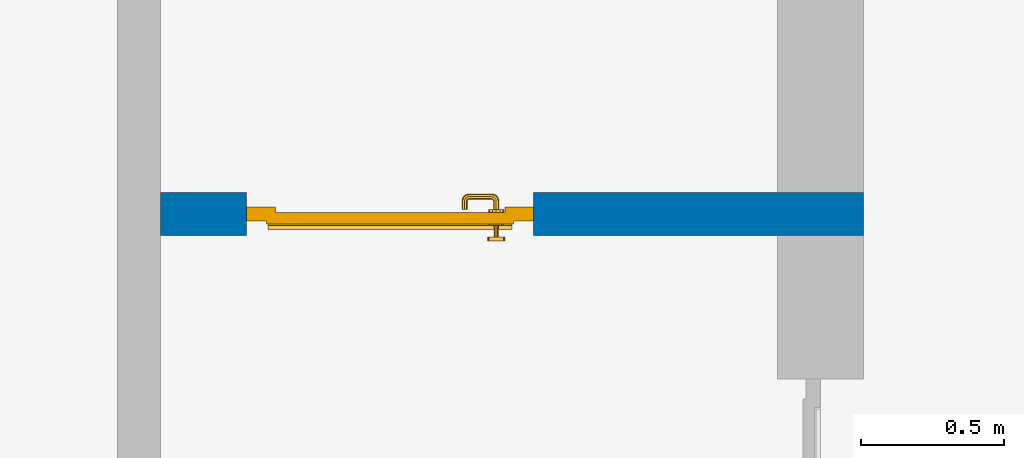
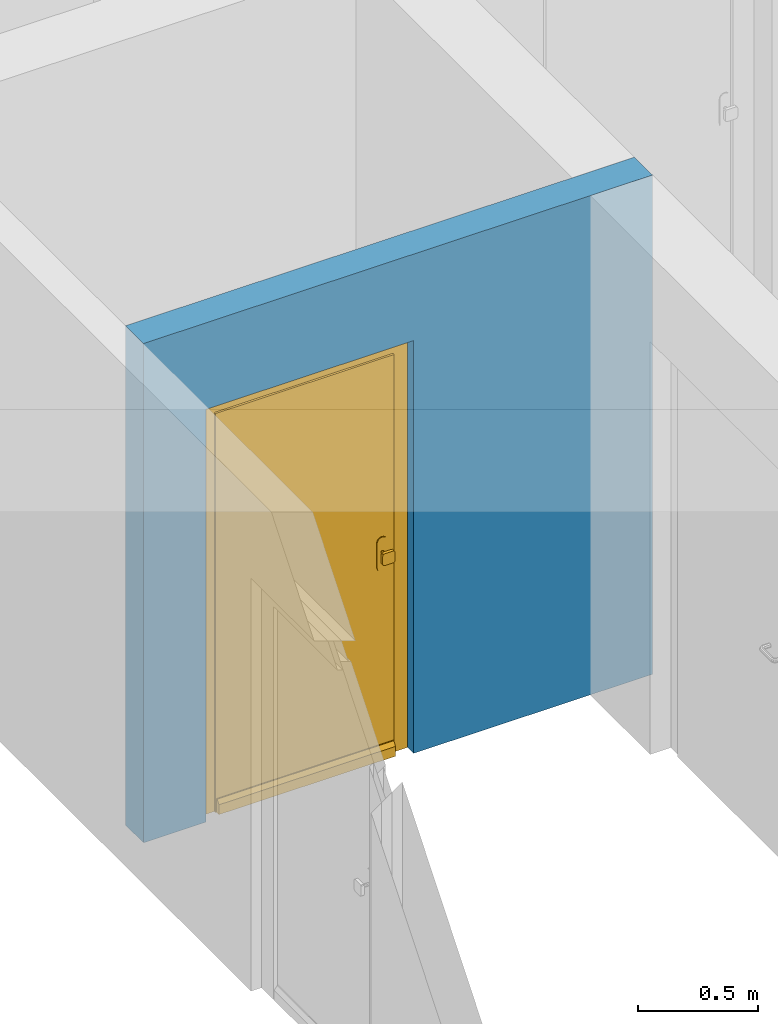
# One storey, part 5 of 54: 1 door, 1 wall, 1 opening.
"""IFC4 building model written with IfcOpenShell, lengths in metres."""

from ifc_helpers import new_model, entity, si_unit, converted_unit, derived_unit, direction, frame, origin_with_axes, place, context, subcontext, project, spatial, polygons, source, transform, mapped, material, type_object, element, fill, save


model = new_model("IFC4")

# Units and contexts
model_context = context("Model", 3, precision=1e-05, world=origin_with_axes(), true_north=direction((0.0, 1.0)))
body_context = subcontext(model_context, "Body", "Model", "MODEL_VIEW")
ifc_project = project(units=[si_unit("LENGTHUNIT", "METRE"), si_unit("AREAUNIT", "SQUARE_METRE"), si_unit("VOLUMEUNIT", "CUBIC_METRE"), converted_unit("PLANEANGLEUNIT", "DEGREE", entity("IfcPlaneAngleMeasure", 0.0174532925199), si_unit("PLANEANGLEUNIT", "RADIAN"), dimensions=[0, 0, 0, 0, 0, 0, 0]), converted_unit("TIMEUNIT", "Year", entity("IfcTimeMeasure", 31556926.0), si_unit("TIMEUNIT", "SECOND"), dimensions=[0, 0, 1, 0, 0, 0, 0]), si_unit("MASSUNIT", "GRAM", prefix="KILO"), si_unit("THERMODYNAMICTEMPERATUREUNIT", "DEGREE_CELSIUS"), si_unit("LUMINOUSINTENSITYUNIT", "LUMEN"), si_unit("ENERGYUNIT", "JOULE", prefix="MEGA"), derived_unit("THERMALCONDUCTANCEUNIT", [(si_unit("POWERUNIT", "WATT"), 1), (si_unit("LENGTHUNIT", "METRE"), -1), (si_unit("THERMODYNAMICTEMPERATUREUNIT", "KELVIN"), -1)]), derived_unit("SPECIFICHEATCAPACITYUNIT", [(si_unit("ENERGYUNIT", "JOULE"), 1), (si_unit("MASSUNIT", "GRAM", prefix="KILO"), -1), (si_unit("THERMODYNAMICTEMPERATUREUNIT", "KELVIN"), -1)]), derived_unit("MASSDENSITYUNIT", [(si_unit("MASSUNIT", "GRAM", prefix="KILO"), 1), (si_unit("VOLUMEUNIT", "CUBIC_METRE"), -1)])], contexts=[model_context])

# Site, building, storey
site_placement = place(None, origin_with_axes())
site = spatial("IfcSite", under=ifc_project, at=site_placement, CompositionType="ELEMENT")
building_placement = place(site_placement, origin_with_axes())
building = spatial("IfcBuilding", under=site, at=building_placement, CompositionType="ELEMENT")
storey_placement = place(building_placement, frame((0.0, 0.0, 6.29), z_axis=(0.0, 0.0, 1.0), x_axis=(1.0, 0.0, 0.0)))
storey = spatial("IfcBuildingStorey", under=building, at=storey_placement, Name="2. Geschoss", CompositionType="ELEMENT", Elevation=6.29)

# Wall, opening, door
ifc_material = material()
wall_type = type_object("IfcWallType", Name="150", PredefinedType="NOTDEFINED")
wall_placement = place(storey_placement, frame((-4.9421993804, -0.428812231043, 0.0), z_axis=(0.0, 0.0, 1.0), x_axis=(-1.0, 0.0, 0.0)))
wall = element("IfcWall", 1, at=wall_placement, inside=storey, type_object=wall_type, material=ifc_material, Name="Wand-002", PredefinedType="NOTDEFINED", context=body_context, shape_type="Tessellation", body=[
    polygons([(2.15, 0.0, 2.1), (2.15, 0.0, 0.0), (2.45, 0.0, 0.0), (2.45, 0.0, 2.54), (0.0, 0.0, 2.54), (0.0, 0.0, 0.0), (1.15, 0.0, 0.0), (1.15, 0.0, 2.1), (2.15, 0.1, 0.0), (2.15, 0.15, 2.1), (2.15, 0.15, 0.0), (2.45, 0.15, 0.0), (2.45, 0.15, 2.54), (0.0, 0.15, 2.54), (0.0, 0.15, 0.0), (1.15, 0.1, 0.0), (1.15, 0.15, 0.0), (1.15, 0.15, 2.1)], [[[1, 2, 3, 4, 5, 6, 7, 8]], [[9, 2, 1, 10, 11]], [[2, 9, 11, 12, 3]], [[4, 3, 12, 13]], [[5, 4, 13, 14]], [[14, 15, 6, 5]], [[16, 7, 6, 15, 17]], [[8, 7, 16, 17, 18]], [[1, 8, 18, 10]], [[12, 11, 10, 18, 17, 15, 14, 13]]], closed=True),
])
opening_placement = place(wall_placement, frame((1.65, 0.0, 0.0), z_axis=(0.0, 0.0, 1.0), x_axis=(1.0, 0.0, 0.0)))
opening = element("IfcOpeningElement", 2, at=opening_placement, cuts=wall, context=body_context, identifier="Reference", shape_type="Tessellation", body=[
    polygons([(-0.5, 0.1, 0.0), (-0.5, 0.1, 2.1), (-0.5, 0.151, 2.1), (-0.5, 0.151, 0.0), (-0.5, -0.001, 0.0), (-0.5, -0.001, 2.1), (0.5, 0.1, 2.1), (0.5, 0.151, 2.1), (0.5, -0.001, 2.1), (0.5, 0.151, 0.0), (0.5, 0.1, 0.0), (0.5, -0.001, 0.0)], [[[1, 2, 3, 4]], [[2, 1, 5, 6]], [[7, 8, 3, 2, 6, 9]], [[8, 10, 4, 3]], [[1, 4, 10, 11, 12, 5]], [[6, 5, 12, 9]], [[7, 11, 10, 8]], [[11, 7, 9, 12]]], closed=True),
])
door_type = type_object("IfcDoorType", Name="Eingang 01 1-Fl 26", OperationType="SINGLE_SWING_RIGHT", PredefinedType="DOOR")
shared_shape = source(origin_with_axes(), body_context, "Body", "Tessellation", [
    polygons([(0.5, -0.05, 0.0), (0.5, -0.03, 0.0), (0.5, -0.03, 2.1), (0.5, -0.05, 2.1), (0.4, -0.05, 0.0), (0.4, -0.03, 0.0), (0.4, -0.03, 2.0), (0.1301, -0.03, 2.0), (0.0001, -0.03, 2.0), (-0.4, -0.03, 2.0), (-0.4, -0.03, 0.0), (-0.5, -0.03, 0.0), (-0.5, -0.03, 2.1), (-0.5, -0.05, 2.1), (-0.5, -0.05, 0.0), (-0.4, -0.05, 0.0), (-0.4, -0.05, 2.0), (0.0001, -0.05, 2.0), (0.1301, -0.05, 2.0), (0.4, -0.05, 2.0)], [[[1, 2, 3, 4]], [[5, 6, 2, 1]], [[2, 6, 7, 8, 9, 10, 11, 12, 13, 3]], [[4, 3, 13, 14]], [[1, 4, 14, 15, 16, 17, 18, 19, 20, 5]], [[20, 7, 6, 5]], [[19, 8, 7, 20]], [[18, 9, 8, 19]], [[17, 10, 9, 18]], [[16, 11, 10, 17]], [[15, 12, 11, 16]], [[14, 13, 12, 15]]], closed=True),
    polygons([(0.5, -0.03, 0.0), (0.5, 0.0, 0.0), (0.5, 0.0, 2.1), (0.5, -0.03, 2.1), (0.43, -0.03, 0.0), (0.43, 0.0, 0.0), (0.43, 0.0, 2.03), (0.1001, 0.0, 2.03), (0.0301, 0.0, 2.03), (-0.43, 0.0, 2.03), (-0.43, 0.0, 0.0), (-0.5, 0.0, 0.0), (-0.5, 0.0, 2.1), (-0.5, -0.03, 2.1), (-0.5, -0.03, 0.0), (-0.43, -0.03, 0.0), (-0.43, -0.03, 2.03), (0.0301, -0.03, 2.03), (0.1001, -0.03, 2.03), (0.43, -0.03, 2.03)], [[[1, 2, 3, 4]], [[5, 6, 2, 1]], [[2, 6, 7, 8, 9, 10, 11, 12, 13, 3]], [[4, 3, 13, 14]], [[1, 4, 14, 15, 16, 17, 18, 19, 20, 5]], [[20, 7, 6, 5]], [[19, 8, 7, 20]], [[18, 9, 8, 19]], [[17, 10, 9, 18]], [[16, 11, 10, 17]], [[15, 12, 11, 16]], [[14, 13, 12, 15]]], closed=True),
    polygons([(0.43, 0.01, 0.0), (-0.43, 0.01, 0.0), (-0.43, 0.01, 2.03), (0.43, 0.01, 2.03), (0.43, -0.03, 0.0), (-0.43, -0.03, 0.0), (-0.43, -0.03, 2.03), (0.43, -0.03, 2.03)], [[[1, 2, 3, 4]], [[2, 1, 5, 6]], [[3, 2, 6, 7]], [[4, 3, 7, 8]], [[1, 4, 8, 5]], [[6, 5, 8, 7]]], closed=True),
    polygons([(0.425, 0.03, 0.0), (-0.425, 0.03, 0.0), (-0.425, 0.03, 0.05), (0.425, 0.03, 0.05), (0.425, 0.01, 0.0), (-0.425, 0.01, 0.0), (-0.425, 0.01, 0.07), (-0.425, 0.015, 0.07), (0.425, 0.015, 0.07), (0.425, 0.01, 0.07)], [[[1, 2, 3, 4]], [[5, 6, 2, 1]], [[2, 6, 7, 8, 3]], [[4, 3, 8, 9]], [[1, 4, 9, 10, 5]], [[10, 7, 6, 5]], [[9, 8, 7, 10]]], closed=True),
    polygons([(-0.3835, -0.04, 1.0733826859), (-0.37, -0.04, 1.077), (-0.37, -0.0399, 1.077), (-0.3835, -0.0399, 1.0733826859), (-0.393382685902, -0.04, 1.0635), (-0.397, -0.04, 1.05), (-0.393382685902, -0.04, 1.0365), (-0.3835, -0.04, 1.0266173141), (-0.37, -0.04, 1.023), (-0.3565, -0.04, 1.0266173141), (-0.346617314098, -0.04, 1.0365), (-0.343, -0.04, 1.05), (-0.346617314098, -0.04, 1.0635), (-0.3565, -0.04, 1.0733826859), (-0.3565, -0.0399, 1.0733826859), (-0.37, -0.0301, 1.077), (-0.3835, -0.0301, 1.0733826859), (-0.393382685902, -0.0399, 1.0635), (-0.397, -0.0399, 1.05), (-0.393382685902, -0.0399, 1.0365), (-0.3835, -0.0399, 1.0266173141), (-0.37, -0.0399, 1.023), (-0.3565, -0.0399, 1.0266173141), (-0.346617314098, -0.0399, 1.0365), (-0.343, -0.0399, 1.05), (-0.346617314098, -0.0399, 1.0635), (-0.3565, -0.0301, 1.0733826859), (-0.37, -0.03, 1.077), (-0.3835, -0.03, 1.0733826859), (-0.393382685902, -0.0301, 1.0635), (-0.397, -0.0301, 1.05), (-0.393382685902, -0.0301, 1.0365), (-0.3835, -0.0301, 1.0266173141), (-0.37, -0.0301, 1.023), (-0.3565, -0.0301, 1.0266173141), (-0.346617314098, -0.0301, 1.0365), (-0.343, -0.0301, 1.05), (-0.346617314098, -0.0301, 1.0635), (-0.3565, -0.03, 1.0733826859), (-0.346617314098, -0.03, 1.0635), (-0.343, -0.03, 1.05), (-0.346617314098, -0.03, 1.0365), (-0.3565, -0.03, 1.0266173141), (-0.37, -0.03, 1.023), (-0.3835, -0.03, 1.0266173141), (-0.393382685902, -0.03, 1.0365), (-0.397, -0.03, 1.05), (-0.393382685902, -0.03, 1.0635)], [[[1, 2, 3, 4]], [[2, 1, 5, 6, 7, 8, 9, 10, 11, 12, 13, 14]], [[2, 14, 15, 3]], [[4, 3, 16, 17]], [[5, 1, 4, 18]], [[6, 5, 18, 19]], [[7, 6, 19, 20]], [[8, 7, 20, 21]], [[9, 8, 21, 22]], [[10, 9, 22, 23]], [[11, 10, 23, 24]], [[12, 11, 24, 25]], [[13, 12, 25, 26]], [[14, 13, 26, 15]], [[3, 15, 27, 16]], [[17, 16, 28, 29]], [[18, 4, 17, 30]], [[19, 18, 30, 31]], [[20, 19, 31, 32]], [[21, 20, 32, 33]], [[22, 21, 33, 34]], [[23, 22, 34, 35]], [[24, 23, 35, 36]], [[25, 24, 36, 37]], [[26, 25, 37, 38]], [[15, 26, 38, 27]], [[16, 27, 39, 28]], [[28, 39, 40, 41, 42, 43, 44, 45, 46, 47, 48, 29]], [[30, 17, 29, 48]], [[31, 30, 48, 47]], [[32, 31, 47, 46]], [[33, 32, 46, 45]], [[34, 33, 45, 44]], [[35, 34, 44, 43]], [[36, 35, 43, 42]], [[37, 36, 42, 41]], [[38, 37, 41, 40]], [[27, 38, 40, 39]]], closed=True),
    polygons([(-0.362532169224, -0.04, 0.959692280177), (-0.365, -0.04, 0.9544), (-0.365, -0.04, 0.952886751346), (-0.346703916638, -0.04, 0.96345), (-0.35655, -0.04, 0.973296083362), (-0.363279754556, -0.04, 0.961639806549), (-0.362532169224, -0.039, 0.959692280177), (-0.365, -0.039, 0.9544), (-0.365, -0.039, 0.952886751346), (-0.365, -0.039, 0.95), (-0.365, -0.039, 0.947113248654), (-0.365, -0.039, 0.941339745962), (-0.365, -0.039, 0.9375), (-0.365, -0.04, 0.9375), (-0.365, -0.04, 0.941339745962), (-0.365, -0.04, 0.947113248654), (-0.365, -0.04, 0.95), (-0.3431, -0.04, 0.95), (-0.346617314098, -0.04, 0.9635), (-0.3565, -0.04, 0.973382685902), (-0.364624817685, -0.04, 0.965143815798), (-0.37, -0.04, 0.9769), (-0.37, -0.04, 0.967425445323), (-0.364624817685, -0.039, 0.965143815798), (-0.363279754556, -0.039, 0.961639806549), (-0.35705, -0.039, 0.972430057958), (-0.347569942042, -0.039, 0.96295), (-0.3441, -0.039, 0.95), (-0.347569942042, -0.039, 0.93705), (-0.35705, -0.039, 0.927569942042), (-0.37, -0.039, 0.9241), (-0.37, -0.039, 0.9325), (-0.366464466094, -0.039, 0.933964466094), (-0.366464466094, -0.04, 0.933964466094), (-0.35655, -0.04, 0.926703916638), (-0.37, -0.04, 0.9325), (-0.37, -0.04, 0.9231), (-0.346703916638, -0.04, 0.93655), (-0.343, -0.04, 0.95), (-0.346617314098, -0.0399, 0.9635), (-0.3565, -0.0399, 0.973382685902), (-0.37, -0.04, 0.977), (-0.375375182315, -0.04, 0.965143815798), (-0.38345, -0.04, 0.973296083362), (-0.376720245444, -0.04, 0.961639806549), (-0.37, -0.039, 0.967425445323), (-0.37, -0.039, 0.9759), (-0.357, -0.039, 0.972516660498), (-0.347483339502, -0.039, 0.963), (-0.344, -0.039, 0.95), (-0.347483339502, -0.039, 0.937), (-0.357, -0.039, 0.927483339502), (-0.38295, -0.039, 0.927569942042), (-0.375, -0.039, 0.941339745962), (-0.375, -0.039, 0.9375), (-0.373535533906, -0.039, 0.933964466094), (-0.37, -0.039, 0.924), (-0.373535533906, -0.04, 0.933964466094), (-0.375, -0.04, 0.9375), (-0.375, -0.04, 0.941339745962), (-0.38345, -0.04, 0.926703916638), (-0.37, -0.04, 0.923), (-0.3565, -0.04, 0.926617314098), (-0.346617314098, -0.04, 0.9365), (-0.343, -0.0399, 0.95), (-0.346617314098, -0.0301, 0.9635), (-0.3565, -0.0301, 0.973382685902), (-0.37, -0.0399, 0.977), (-0.3835, -0.04, 0.973382685902), (-0.375375182315, -0.039, 0.965143815798), (-0.377467830776, -0.04, 0.959692280177), (-0.393296083362, -0.04, 0.96345), (-0.375, -0.04, 0.952886751346), (-0.375, -0.04, 0.9544), (-0.377467830776, -0.039, 0.959692280177), (-0.376720245444, -0.039, 0.961639806549), (-0.38295, -0.039, 0.972430057958), (-0.37, -0.039, 0.976), (-0.357, -0.0389, 0.972516660498), (-0.347483339502, -0.0389, 0.963), (-0.344, -0.0389, 0.95), (-0.347483339502, -0.0389, 0.937), (-0.357, -0.0389, 0.927483339502), (-0.392430057958, -0.039, 0.93705), (-0.375, -0.039, 0.947113248654), (-0.375, -0.039, 0.9544), (-0.375, -0.04, 0.95), (-0.375, -0.04, 0.947113248654), (-0.375, -0.039, 0.95), (-0.375, -0.039, 0.952886751346), (-0.383, -0.039, 0.927483339502), (-0.37, -0.0389, 0.924), (-0.393296083362, -0.04, 0.93655), (-0.3835, -0.04, 0.926617314098), (-0.37, -0.0399, 0.923), (-0.3565, -0.0399, 0.926617314098), (-0.346617314098, -0.0399, 0.9365), (-0.343, -0.0301, 0.95), (-0.346617314098, -0.03, 0.9635), (-0.3565, -0.03, 0.973382685902), (-0.37, -0.0301, 0.977), (-0.3835, -0.0399, 0.973382685902), (-0.393382685902, -0.04, 0.9635), (-0.3969, -0.04, 0.95), (-0.392430057958, -0.039, 0.96295), (-0.383, -0.039, 0.972516660498), (-0.37, -0.0389, 0.976), (-0.357, -0.0301, 0.972516660498), (-0.347483339502, -0.0301, 0.963), (-0.344, -0.0301, 0.95), (-0.347483339502, -0.0301, 0.937), (-0.357, -0.0301, 0.927483339502), (-0.392516660498, -0.039, 0.937), (-0.3959, -0.039, 0.95), (-0.383, -0.0389, 0.927483339502), (-0.37, -0.0301, 0.924), (-0.393382685902, -0.04, 0.9365), (-0.3835, -0.0399, 0.926617314098), (-0.37, -0.0301, 0.923), (-0.3565, -0.0301, 0.926617314098), (-0.346617314098, -0.0301, 0.9365), (-0.343, -0.03, 0.95), (-0.346703916638, -0.03, 0.96345), (-0.35655, -0.03, 0.973296083362), (-0.37, -0.03, 0.977), (-0.3835, -0.0301, 0.973382685902), (-0.393382685902, -0.0399, 0.9635), (-0.397, -0.04, 0.95), (-0.392516660498, -0.039, 0.963), (-0.383, -0.0389, 0.972516660498), (-0.37, -0.0301, 0.976), (-0.357, -0.03, 0.972516660498), (-0.347483339502, -0.03, 0.963), (-0.344, -0.03, 0.95), (-0.347483339502, -0.03, 0.937), (-0.357, -0.03, 0.927483339502), (-0.392516660498, -0.0389, 0.937), (-0.396, -0.039, 0.95), (-0.383, -0.0301, 0.927483339502), (-0.37, -0.03, 0.924), (-0.393382685902, -0.0399, 0.9365), (-0.3835, -0.0301, 0.926617314098), (-0.37, -0.03, 0.923), (-0.3565, -0.03, 0.926617314098), (-0.346617314098, -0.03, 0.9365), (-0.3431, -0.03, 0.95), (-0.347396736961, -0.03, 0.96305), (-0.35695, -0.03, 0.972603263039), (-0.37, -0.03, 0.9769), (-0.3835, -0.03, 0.973382685902), (-0.393382685902, -0.0301, 0.9635), (-0.397, -0.0399, 0.95), (-0.392516660498, -0.0389, 0.963), (-0.383, -0.0301, 0.972516660498), (-0.37, -0.03, 0.976), (-0.3439, -0.03, 0.95), (-0.347396736961, -0.03, 0.93695), (-0.35695, -0.03, 0.927396736961), (-0.392516660498, -0.0301, 0.937), (-0.396, -0.0389, 0.95), (-0.383, -0.03, 0.927483339502), (-0.37, -0.03, 0.9239), (-0.393382685902, -0.0301, 0.9365), (-0.3835, -0.03, 0.926617314098), (-0.37, -0.03, 0.9231), (-0.35655, -0.03, 0.926703916638), (-0.346703916638, -0.03, 0.93655), (-0.37, -0.03, 0.9761), (-0.38345, -0.03, 0.973296083362), (-0.393382685902, -0.03, 0.9635), (-0.397, -0.0301, 0.95), (-0.392516660498, -0.0301, 0.963), (-0.383, -0.03, 0.972516660498), (-0.392516660498, -0.03, 0.937), (-0.396, -0.0301, 0.95), (-0.38305, -0.03, 0.927396736961), (-0.393382685902, -0.03, 0.9365), (-0.38345, -0.03, 0.926703916638), (-0.38305, -0.03, 0.972603263039), (-0.393296083362, -0.03, 0.96345), (-0.397, -0.03, 0.95), (-0.392516660498, -0.03, 0.963), (-0.392603263039, -0.03, 0.93695), (-0.396, -0.03, 0.95), (-0.393296083362, -0.03, 0.93655), (-0.392603263039, -0.03, 0.96305), (-0.3969, -0.03, 0.95), (-0.3961, -0.03, 0.95)], [[[1, 2, 3, 4, 5, 6]], [[2, 1, 7, 8]], [[2, 8, 9, 10, 11, 12, 13, 14, 15, 16, 17, 3]], [[17, 18, 4, 3]], [[19, 20, 5, 4]], [[21, 6, 5, 22, 23]], [[1, 6, 21, 24, 25, 7]], [[7, 25, 26, 27, 9, 8]], [[9, 27, 28, 10]], [[10, 28, 29, 11]], [[11, 29, 30, 12]], [[31, 32, 33, 13, 12, 30]], [[14, 13, 33, 34]], [[35, 15, 14, 34, 36, 37]], [[15, 35, 38, 16]], [[16, 38, 18, 17]], [[39, 19, 4, 18]], [[40, 41, 20, 19]], [[20, 42, 22, 5]], [[43, 23, 22, 44, 45]], [[21, 23, 46, 24]], [[24, 46, 47, 26, 25]], [[27, 26, 48, 49]], [[28, 27, 49, 50]], [[29, 28, 50, 51]], [[30, 29, 51, 52]], [[53, 54, 55, 56, 32, 31]], [[34, 33, 32, 36]], [[31, 30, 52, 57]], [[37, 36, 58, 59, 60, 61]], [[62, 63, 35, 37]], [[63, 64, 38, 35]], [[64, 39, 18, 38]], [[65, 40, 19, 39]], [[66, 67, 41, 40]], [[41, 68, 42, 20]], [[42, 69, 44, 22]], [[23, 43, 70, 46]], [[71, 45, 44, 72, 73, 74]], [[43, 45, 71, 75, 76, 70]], [[70, 76, 77, 47, 46]], [[26, 47, 78, 48]], [[49, 48, 79, 80]], [[50, 49, 80, 81]], [[51, 50, 81, 82]], [[52, 51, 82, 83]], [[54, 53, 84, 85]], [[86, 74, 73, 87, 88, 60, 59, 55, 54, 85, 89, 90]], [[58, 56, 55, 59]], [[36, 32, 56, 58]], [[53, 31, 57, 91]], [[57, 52, 83, 92]], [[88, 93, 61, 60]], [[94, 62, 37, 61]], [[95, 96, 63, 62]], [[96, 97, 64, 63]], [[97, 65, 39, 64]], [[98, 66, 40, 65]], [[99, 100, 67, 66]], [[67, 101, 68, 41]], [[68, 102, 69, 42]], [[69, 103, 72, 44]], [[73, 72, 104, 87]], [[71, 74, 86, 75]], [[75, 86, 90, 105, 77, 76]], [[47, 77, 106, 78]], [[48, 78, 107, 79]], [[80, 79, 108, 109]], [[81, 80, 109, 110]], [[82, 81, 110, 111]], [[83, 82, 111, 112]], [[84, 53, 91, 113]], [[85, 84, 114, 89]], [[87, 104, 93, 88]], [[89, 114, 105, 90]], [[91, 57, 92, 115]], [[92, 83, 112, 116]], [[117, 94, 61, 93]], [[118, 95, 62, 94]], [[119, 120, 96, 95]], [[120, 121, 97, 96]], [[121, 98, 65, 97]], [[122, 99, 66, 98]], [[123, 124, 100, 99]], [[100, 125, 101, 67]], [[101, 126, 102, 68]], [[102, 127, 103, 69]], [[103, 128, 104, 72]], [[77, 105, 129, 106]], [[78, 106, 130, 107]], [[79, 107, 131, 108]], [[109, 108, 132, 133]], [[110, 109, 133, 134]], [[111, 110, 134, 135]], [[112, 111, 135, 136]], [[113, 91, 115, 137]], [[114, 84, 113, 138]], [[128, 117, 93, 104]], [[105, 114, 138, 129]], [[115, 92, 116, 139]], [[116, 112, 136, 140]], [[141, 118, 94, 117]], [[142, 119, 95, 118]], [[143, 144, 120, 119]], [[144, 145, 121, 120]], [[145, 122, 98, 121]], [[146, 123, 99, 122]], [[147, 148, 124, 123]], [[124, 149, 125, 100]], [[125, 150, 126, 101]], [[126, 151, 127, 102]], [[127, 152, 128, 103]], [[106, 129, 153, 130]], [[107, 130, 154, 131]], [[108, 131, 155, 132]], [[133, 132, 148, 147]], [[134, 133, 147, 156]], [[135, 134, 156, 157]], [[136, 135, 157, 158]], [[137, 115, 139, 159]], [[138, 113, 137, 160]], [[152, 141, 117, 128]], [[129, 138, 160, 153]], [[139, 116, 140, 161]], [[140, 136, 158, 162]], [[163, 142, 118, 141]], [[164, 143, 119, 142]], [[165, 166, 144, 143]], [[166, 167, 145, 144]], [[167, 146, 122, 145]], [[156, 147, 123, 146]], [[148, 168, 149, 124]], [[149, 169, 150, 125]], [[150, 170, 151, 126]], [[151, 171, 152, 127]], [[130, 153, 172, 154]], [[131, 154, 173, 155]], [[132, 155, 168, 148]], [[157, 156, 146, 167]], [[158, 157, 167, 166]], [[159, 139, 161, 174]], [[160, 137, 159, 175]], [[171, 163, 141, 152]], [[153, 160, 175, 172]], [[161, 140, 162, 176]], [[162, 158, 166, 165]], [[177, 164, 142, 163]], [[178, 165, 143, 164]], [[168, 179, 169, 149]], [[169, 180, 170, 150]], [[170, 181, 171, 151]], [[154, 172, 182, 173]], [[155, 173, 179, 168]], [[174, 161, 176, 183]], [[175, 159, 174, 184]], [[181, 177, 163, 171]], [[172, 175, 184, 182]], [[176, 162, 165, 178]], [[185, 178, 164, 177]], [[179, 186, 180, 169]], [[180, 187, 181, 170]], [[173, 182, 186, 179]], [[183, 176, 178, 185]], [[184, 174, 183, 188]], [[187, 185, 177, 181]], [[182, 184, 188, 186]], [[186, 188, 187, 180]], [[188, 183, 185, 187]]], closed=True),
    polygons([(-0.38, -0.04, 1.05), (-0.377071067812, -0.04, 1.04292893219), (-0.377071067812, -0.070696439392, 1.04292893219), (-0.38, -0.0709849140336, 1.05), (-0.37, -0.04, 1.04), (-0.37, -0.07, 1.04), (-0.375518993221, -0.0784992452783, 1.04292893219), (-0.378277987014, -0.0796420579258, 1.05), (-0.377071067812, -0.04, 1.05707106781), (-0.377071067812, -0.070696439392, 1.05707106781), (-0.362928932188, -0.04, 1.04292893219), (-0.362928932188, -0.069303560608, 1.04292893219), (-0.368858192988, -0.0757402514855, 1.04), (-0.370704557509, -0.0857045575088, 1.04292893219), (-0.372816199938, -0.0878161999379, 1.05), (-0.375518993221, -0.0784992452783, 1.05707106781), (-0.37, -0.04, 1.06), (-0.37, -0.07, 1.06), (-0.36, -0.04, 1.05), (-0.36, -0.0690150859664, 1.05), (-0.362197392755, -0.0729812576926, 1.04292893219), (-0.365606601718, -0.0806066017178, 1.04), (-0.363499245278, -0.0905189932208, 1.04292893219), (-0.364642057926, -0.0932779870137, 1.05), (-0.370704557509, -0.0857045575088, 1.05707106781), (-0.368858192988, -0.0757402514855, 1.06), (-0.362928932188, -0.04, 1.05707106781), (-0.362928932188, -0.069303560608, 1.05707106781), (-0.359438398962, -0.0718384450452, 1.05), (-0.360508645927, -0.0755086459268, 1.04292893219), (-0.360740251485, -0.0838581929877, 1.04), (-0.355696439392, -0.0920710678119, 1.04292893219), (-0.355984914034, -0.095, 1.05), (-0.363499245278, -0.0905189932208, 1.05707106781), (-0.365606601718, -0.0806066017178, 1.06), (-0.362197392755, -0.0729812576926, 1.05707106781), (-0.358397003498, -0.0733970034977, 1.05), (-0.357981257693, -0.0771973927545, 1.04292893219), (-0.355, -0.085, 1.04), (-0.274303560608, -0.0920710678119, 1.04292893219), (-0.274015085966, -0.095, 1.05), (-0.355696439392, -0.0920710678119, 1.05707106781), (-0.360740251485, -0.0838581929877, 1.06), (-0.360508645927, -0.0755086459268, 1.05707106781), (-0.356838445045, -0.0744383989617, 1.05), (-0.354303560608, -0.0779289321881, 1.04292893219), (-0.275, -0.085, 1.04), (-0.266500754722, -0.0905189932208, 1.04292893219), (-0.265357942074, -0.0932779870137, 1.05), (-0.274303560608, -0.0920710678119, 1.05707106781), (-0.355, -0.085, 1.06), (-0.357981257693, -0.0771973927545, 1.05707106781), (-0.354015085966, -0.075, 1.05), (-0.275696439392, -0.0779289321881, 1.04292893219), (-0.269259748515, -0.0838581929877, 1.04), (-0.259295442491, -0.0857045575088, 1.04292893219), (-0.257183800062, -0.0878161999379, 1.05), (-0.266500754722, -0.0905189932208, 1.05707106781), (-0.275, -0.085, 1.06), (-0.354303560608, -0.0779289321881, 1.05707106781), (-0.275984914034, -0.075, 1.05), (-0.272018742307, -0.0771973927545, 1.04292893219), (-0.264393398282, -0.0806066017178, 1.04), (-0.254481006779, -0.0784992452783, 1.04292893219), (-0.251722012986, -0.0796420579258, 1.05), (-0.259295442491, -0.0857045575088, 1.05707106781), (-0.269259748515, -0.0838581929877, 1.06), (-0.275696439392, -0.0779289321881, 1.05707106781), (-0.273161554955, -0.0744383989617, 1.05), (-0.269491354073, -0.0755086459268, 1.04292893219), (-0.261141807012, -0.0757402514855, 1.04), (-0.252928932188, -0.070696439392, 1.04292893219), (-0.25, -0.0709849140336, 1.05), (-0.254481006779, -0.0784992452783, 1.05707106781), (-0.264393398282, -0.0806066017178, 1.06), (-0.272018742307, -0.0771973927545, 1.05707106781), (-0.271602996502, -0.0733970034977, 1.05), (-0.267802607245, -0.0729812576926, 1.04292893219), (-0.26, -0.07, 1.04), (-0.252928932188, -0.04, 1.04292893219), (-0.25, -0.04, 1.05), (-0.252928932188, -0.070696439392, 1.05707106781), (-0.261141807012, -0.0757402514855, 1.06), (-0.269491354073, -0.0755086459268, 1.05707106781), (-0.270561601038, -0.0718384450452, 1.05), (-0.267071067812, -0.069303560608, 1.04292893219), (-0.26, -0.04, 1.04), (-0.267071067812, -0.04, 1.04292893219), (-0.27, -0.04, 1.05), (-0.267071067812, -0.04, 1.05707106781), (-0.26, -0.04, 1.06), (-0.252928932188, -0.04, 1.05707106781), (-0.26, -0.07, 1.06), (-0.267802607245, -0.0729812576926, 1.05707106781), (-0.27, -0.0690150859664, 1.05), (-0.267071067812, -0.069303560608, 1.05707106781)], [[[1, 2, 3, 4]], [[2, 5, 6, 3]], [[4, 3, 7, 8]], [[9, 1, 4, 10]], [[5, 11, 12, 6]], [[3, 6, 13, 7]], [[8, 7, 14, 15]], [[10, 4, 8, 16]], [[17, 9, 10, 18]], [[11, 19, 20, 12]], [[6, 12, 21, 13]], [[7, 13, 22, 14]], [[15, 14, 23, 24]], [[16, 8, 15, 25]], [[18, 10, 16, 26]], [[27, 17, 18, 28]], [[19, 27, 28, 20]], [[12, 20, 29, 21]], [[13, 21, 30, 22]], [[14, 22, 31, 23]], [[24, 23, 32, 33]], [[25, 15, 24, 34]], [[26, 16, 25, 35]], [[28, 18, 26, 36]], [[20, 28, 36, 29]], [[21, 29, 37, 30]], [[22, 30, 38, 31]], [[23, 31, 39, 32]], [[33, 32, 40, 41]], [[34, 24, 33, 42]], [[35, 25, 34, 43]], [[36, 26, 35, 44]], [[29, 36, 44, 37]], [[30, 37, 45, 38]], [[31, 38, 46, 39]], [[32, 39, 47, 40]], [[41, 40, 48, 49]], [[42, 33, 41, 50]], [[43, 34, 42, 51]], [[44, 35, 43, 52]], [[37, 44, 52, 45]], [[38, 45, 53, 46]], [[39, 46, 54, 47]], [[40, 47, 55, 48]], [[49, 48, 56, 57]], [[50, 41, 49, 58]], [[51, 42, 50, 59]], [[52, 43, 51, 60]], [[45, 52, 60, 53]], [[46, 53, 61, 54]], [[47, 54, 62, 55]], [[48, 55, 63, 56]], [[57, 56, 64, 65]], [[58, 49, 57, 66]], [[59, 50, 58, 67]], [[60, 51, 59, 68]], [[53, 60, 68, 61]], [[54, 61, 69, 62]], [[55, 62, 70, 63]], [[56, 63, 71, 64]], [[65, 64, 72, 73]], [[66, 57, 65, 74]], [[67, 58, 66, 75]], [[68, 59, 67, 76]], [[61, 68, 76, 69]], [[62, 69, 77, 70]], [[63, 70, 78, 71]], [[64, 71, 79, 72]], [[73, 72, 80, 81]], [[74, 65, 73, 82]], [[75, 66, 74, 83]], [[76, 67, 75, 84]], [[69, 76, 84, 77]], [[70, 77, 85, 78]], [[71, 78, 86, 79]], [[72, 79, 87, 80]], [[81, 80, 87, 88, 89, 90, 91, 92]], [[82, 73, 81, 92]], [[83, 74, 82, 93]], [[84, 75, 83, 94]], [[77, 84, 94, 85]], [[78, 85, 95, 86]], [[79, 86, 88, 87]], [[86, 95, 89, 88]], [[95, 96, 90, 89]], [[96, 93, 91, 90]], [[93, 82, 92, 91]], [[94, 83, 93, 96]], [[85, 94, 96, 95]]], closed=False),
    polygons([(-0.364696699141, 0.015, 1.04469669914), (-0.3625, 0.015, 1.05), (-0.364696699141, 0.015, 1.05530330086), (-0.37, 0.015, 1.0575), (-0.375303300859, 0.015, 1.05530330086), (-0.3775, 0.015, 1.05), (-0.375303300859, 0.015, 1.04469669914), (-0.37, 0.015, 1.0425), (-0.364696699141, 0.055, 1.04469669914), (-0.3625, 0.055, 1.05), (-0.364696699141, 0.055, 1.05530330086), (-0.37, 0.055, 1.0575), (-0.375303300859, 0.055, 1.05530330086), (-0.3775, 0.055, 1.05), (-0.375303300859, 0.055, 1.04469669914), (-0.37, 0.055, 1.0425)], [[[1, 2, 3, 4, 5, 6, 7, 8]], [[1, 9, 10, 2]], [[2, 10, 11, 3]], [[3, 11, 12, 4]], [[4, 12, 13, 5]], [[5, 13, 14, 6]], [[6, 14, 15, 7]], [[7, 15, 16, 8]], [[8, 16, 9, 1]], [[9, 16, 15, 14, 13, 12, 11, 10]]], closed=True),
    polygons([(-0.395, 0.01, 0.975), (-0.395, 0.015, 0.975), (-0.393096988313, 0.015, 0.965432914191), (-0.393096988313, 0.01, 0.965432914191), (-0.395, 0.01, 1.1), (-0.395, 0.015, 1.1), (-0.393096988313, 0.015, 1.10956708581), (-0.38767766953, 0.015, 1.11767766953), (-0.379567085809, 0.015, 1.12309698831), (-0.37, 0.015, 1.125), (-0.360432914191, 0.015, 1.12309698831), (-0.35232233047, 0.015, 1.11767766953), (-0.346903011687, 0.015, 1.10956708581), (-0.345, 0.015, 1.1), (-0.345, 0.015, 0.975), (-0.346903011687, 0.015, 0.965432914191), (-0.35232233047, 0.015, 0.95732233047), (-0.360432914191, 0.015, 0.951903011687), (-0.37, 0.015, 0.95), (-0.379567085809, 0.015, 0.951903011687), (-0.38767766953, 0.015, 0.95732233047), (-0.38767766953, 0.01, 0.95732233047), (-0.379567085809, 0.01, 0.951903011687), (-0.37, 0.01, 0.95), (-0.360432914191, 0.01, 0.951903011687), (-0.35232233047, 0.01, 0.95732233047), (-0.346903011687, 0.01, 0.965432914191), (-0.345, 0.01, 0.975), (-0.345, 0.01, 1.1), (-0.346903011687, 0.01, 1.10956708581), (-0.35232233047, 0.01, 1.11767766953), (-0.360432914191, 0.01, 1.12309698831), (-0.37, 0.01, 1.125), (-0.379567085809, 0.01, 1.12309698831), (-0.38767766953, 0.01, 1.11767766953), (-0.393096988313, 0.01, 1.10956708581)], [[[1, 2, 3, 4]], [[5, 6, 2, 1]], [[2, 6, 7, 8, 9, 10, 11, 12, 13, 14, 15, 16, 17, 18, 19, 20, 21, 3]], [[4, 3, 21, 22]], [[1, 4, 22, 23, 24, 25, 26, 27, 28, 29, 30, 31, 32, 33, 34, 35, 36, 5]], [[36, 7, 6, 5]], [[35, 8, 7, 36]], [[34, 9, 8, 35]], [[33, 10, 9, 34]], [[32, 11, 10, 33]], [[31, 12, 11, 32]], [[30, 13, 12, 31]], [[29, 14, 13, 30]], [[28, 15, 14, 29]], [[27, 16, 15, 28]], [[26, 17, 16, 27]], [[25, 18, 17, 26]], [[24, 19, 18, 25]], [[23, 20, 19, 24]], [[22, 21, 20, 23]]], closed=True),
    polygons([(-0.39, 0.055, 1.08), (-0.39, 0.07, 1.08), (-0.395, 0.07, 1.07866025404), (-0.395, 0.055, 1.07866025404), (-0.35, 0.055, 1.08), (-0.35, 0.07, 1.08), (-0.345, 0.07, 1.07866025404), (-0.341339745962, 0.07, 1.075), (-0.34, 0.07, 1.07), (-0.34, 0.07, 1.03), (-0.341339745962, 0.07, 1.025), (-0.345, 0.07, 1.02133974596), (-0.35, 0.07, 1.02), (-0.39, 0.07, 1.02), (-0.395, 0.07, 1.02133974596), (-0.398660254038, 0.07, 1.025), (-0.4, 0.07, 1.03), (-0.4, 0.07, 1.07), (-0.398660254038, 0.07, 1.075), (-0.398660254038, 0.055, 1.075), (-0.4, 0.055, 1.07), (-0.4, 0.055, 1.03), (-0.398660254038, 0.055, 1.025), (-0.395, 0.055, 1.02133974596), (-0.39, 0.055, 1.02), (-0.35, 0.055, 1.02), (-0.345, 0.055, 1.02133974596), (-0.341339745962, 0.055, 1.025), (-0.34, 0.055, 1.03), (-0.34, 0.055, 1.07), (-0.341339745962, 0.055, 1.075), (-0.345, 0.055, 1.07866025404)], [[[1, 2, 3, 4]], [[5, 6, 2, 1]], [[2, 6, 7, 8, 9, 10, 11, 12, 13, 14, 15, 16, 17, 18, 19, 3]], [[4, 3, 19, 20]], [[1, 4, 20, 21, 22, 23, 24, 25, 26, 27, 28, 29, 30, 31, 32, 5]], [[32, 7, 6, 5]], [[31, 8, 7, 32]], [[30, 9, 8, 31]], [[29, 10, 9, 30]], [[28, 11, 10, 29]], [[27, 12, 11, 28]], [[26, 13, 12, 27]], [[25, 14, 13, 26]], [[24, 15, 14, 25]], [[23, 16, 15, 24]], [[22, 17, 16, 23]], [[21, 18, 17, 22]], [[20, 19, 18, 21]]], closed=True),
])
door_placement = place(opening_placement, frame((-0.4, 0.0, 0.0), z_axis=(0.0, 0.0, 1.0), x_axis=(1.0, 0.0, 0.0)))
door = element("IfcDoor", 3, at=door_placement, inside=storey, type_object=door_type, OverallHeight=2.1, OverallWidth=1.0, PredefinedType="DOOR", context=body_context, shape_type="MappedRepresentation", body=[
    mapped(shared_shape, transform((0.4, 0.1, 0.0))),
])
fill(opening, door)

save(model, "model.ifc")
